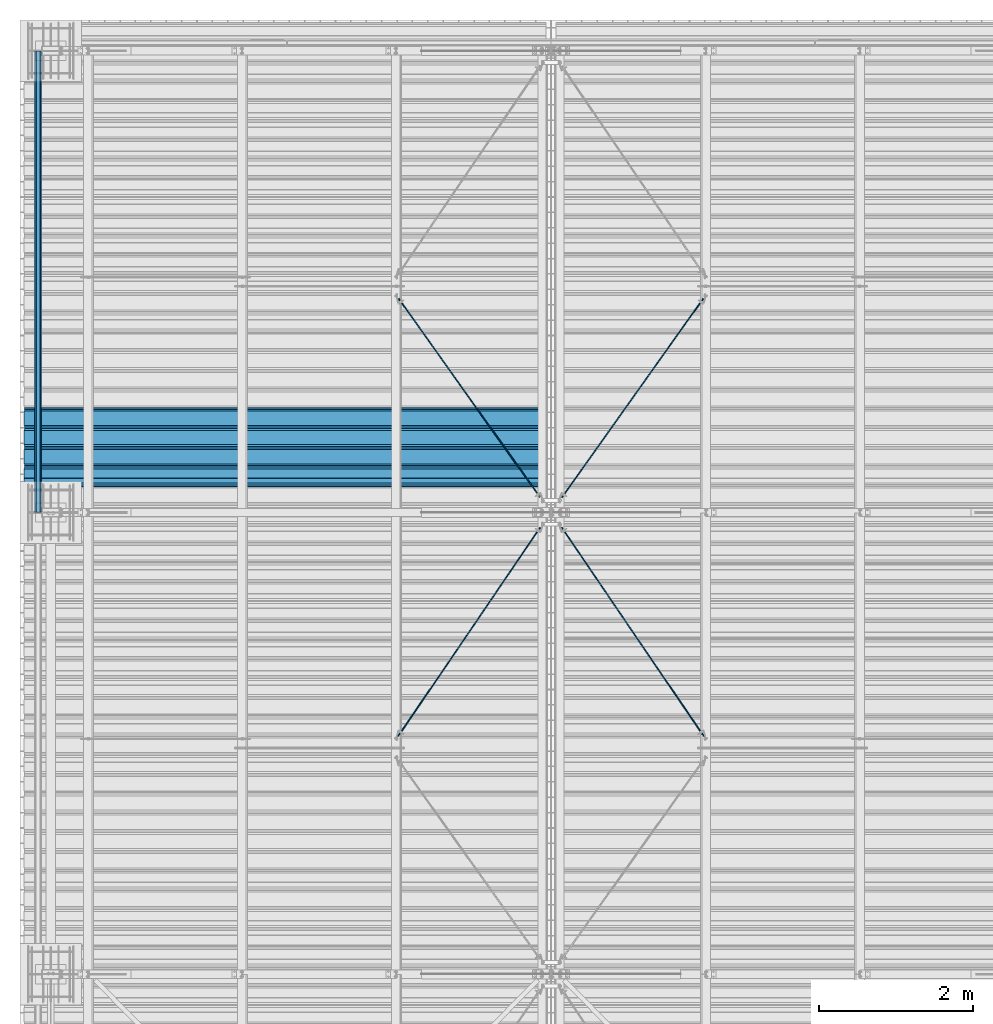
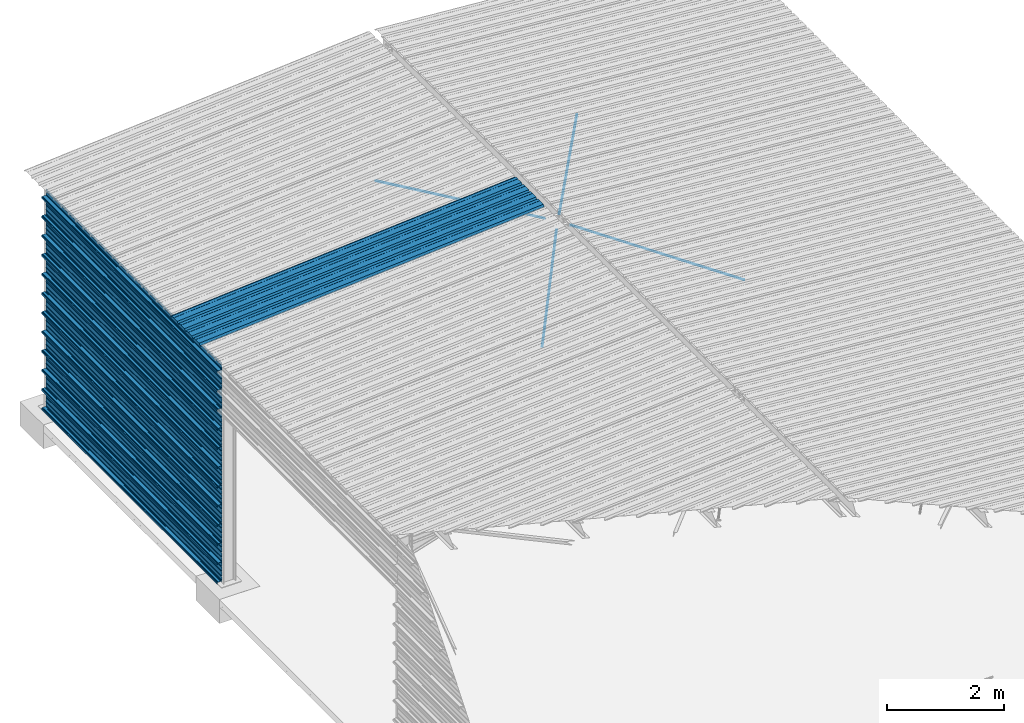
# One storey, part 16 of 70: 17 beams, 17 elements without a shape of their own.
"""IFC2X3 building model written with IfcOpenShell, lengths in millimetres."""

from ifc_helpers import new_model, si_unit, frame, origin_with_axes, origin_2d_with_axis, place, context, subcontext, project, spatial, polyline, circle, outline, extrude, clip, halfspace, material, type_object, element, aggregate, save


model = new_model("IFC2X3")

# Units and contexts
model_context = context("Model", 3, precision=1e-05, world=origin_with_axes())
body_context = subcontext(model_context, "Body", "Model", "MODEL_VIEW")
ifc_project = project(units=[si_unit("LENGTHUNIT", "METRE", prefix="MILLI"), si_unit("AREAUNIT", "SQUARE_METRE"), si_unit("VOLUMEUNIT", "CUBIC_METRE"), si_unit("MASSUNIT", "GRAM", prefix="KILO"), si_unit("TIMEUNIT", "SECOND"), si_unit("PLANEANGLEUNIT", "RADIAN"), si_unit("SOLIDANGLEUNIT", "STERADIAN"), si_unit("THERMODYNAMICTEMPERATUREUNIT", "DEGREE_CELSIUS"), si_unit("LUMINOUSINTENSITYUNIT", "LUMEN")], contexts=[model_context])

# Site, building, storey
site_placement = place(None, origin_with_axes())
site = spatial("IfcSite", under=ifc_project, at=site_placement, CompositionType="ELEMENT")
building_placement = place(site_placement, origin_with_axes())
building = spatial("IfcBuilding", under=site, at=building_placement, Name="Undefined", CompositionType="ELEMENT")
storey_placement = place(building_placement, origin_with_axes())
storey = spatial("IfcBuildingStorey", under=building, at=storey_placement, Name="Undefined", CompositionType="ELEMENT", Elevation=0.0)

# Assembly, beam
assembly_1_placement = place(storey_placement, origin_with_axes())
assembly_1 = element("IfcElementAssembly", 1, at=assembly_1_placement, inside=storey, Name="Steel Assembly", AssemblyPlace="NOTDEFINED", PredefinedType="RIGID_FRAME")
ifc_material = material(Name="STEEL/S235JR")
beam_type_1 = type_object("IfcBeamType", Name="4.40", PredefinedType="NOTDEFINED")
beam_1_placement = place(assembly_1_placement, frame((6436.39248868039, 18850.0, 5336.31760454388), z_axis=(0.0766964990376782, 0.0, -0.997054485489817), x_axis=(-0.997054485489818, 0.0, -0.0766964990376602)))
beam_1 = element("IfcBeam", 2, at=beam_1_placement, type_object=beam_type_1, material=ifc_material, ObjectType="4.40", context=body_context, shape_type="SweptSolid", body=[
    extrude(outline(polyline([(509.415161132813, 19.5000000011705), (490.584838867188, 19.5000000011705), (468.084838867188, -20.4999999988113), (406.585784912109, -20.4999999988113), (404.585784912109, -18.4999999988122), (345.414215087891, -18.4999999988122), (343.414215087891, -20.4999999988113), (281.915161132813, -20.4999999988113), (259.415161132813, 19.5000000011705), (240.584854125977, 19.5000000011705), (218.084854125977, -20.4999999988113), (156.585784912109, -20.4999999988113), (154.585784912109, -18.4999999988122), (95.4142150878906, -18.4999999988122), (93.4142150878906, -20.4999999988113), (31.9151515960693, -20.4999999988113), (9.41515254974365, 19.5000000011705), (-9.41515254974365, 19.5000000011705), (-31.9151515960693, -20.4999999988113), (-93.4142150878906, -20.4999999988113), (-95.4142150878906, -18.4999999988122), (-154.585784912109, -18.4999999988122), (-156.585784912109, -20.4999999988113), (-218.084854125977, -20.4999999988113), (-240.584854125977, 19.5000000011705), (-259.415161132813, 19.5000000011705), (-281.915161132813, -20.4999999988113), (-343.414215087891, -20.4999999988113), (-345.414215087891, -18.4999999988122), (-404.585784912109, -18.4999999988122), (-406.585784912109, -20.4999999988113), (-468.084838867188, -20.4999999988113), (-490.584838867188, 19.5000000011705), (-509.415161132813, 19.5000000011705), (-516.482360839844, 6.9361057293263), (-517.353942871094, 7.42636680720625), (-510.0, 20.5000000011705), (-490.0, 20.5000000011705), (-467.5, -19.4999999988122), (-407.0, -19.4999999988122), (-405.0, -17.4999999988131), (-345.0, -17.4999999988131), (-343.0, -19.4999999988122), (-282.5, -19.4999999988122), (-260.0, 20.5000000011705), (-240.0, 20.5000000011705), (-217.5, -19.4999999988122), (-157.0, -19.4999999988122), (-155.0, -17.4999999988131), (-95.0, -17.4999999988131), (-93.0, -19.4999999988122), (-32.5, -19.4999999988122), (-10.0, 20.5000000011705), (10.0, 20.5000000011705), (32.5, -19.4999999988122), (93.0, -19.4999999988122), (95.0, -17.4999999988131), (155.0, -17.4999999988131), (157.0, -19.4999999988122), (217.5, -19.4999999988122), (240.0, 20.5000000011705), (260.0, 20.5000000011705), (282.5, -19.4999999988122), (343.0, -19.4999999988122), (345.0, -17.4999999988131), (405.0, -17.4999999988131), (407.0, -19.4999999988122), (467.5, -19.4999999988122), (490.0, 20.5000000011705), (510.0, 20.5000000011705), (517.353942871094, 7.42636680720625), (516.482360839844, 6.9361057293263), (509.415161132813, 19.5000000011705)])), frame((6799.99999999733, 2.8421709430404e-14, 0.0), z_axis=(-1.0, 0.0, 0.0), x_axis=(0.0, -1.0, 0.0)), (0.0, 0.0, 1.0), 6800.0),
])
aggregate(assembly_1, [beam_1])

assembly_2_placement = place(storey_placement, origin_with_axes())
assembly_2 = element("IfcElementAssembly", 3, at=assembly_2_placement, inside=storey, Name="Steel Assembly", AssemblyPlace="NOTDEFINED", PredefinedType="RIGID_FRAME")
beam_type_2 = type_object("IfcBeamType", Name="400", PredefinedType="NOTDEFINED")
beam_2_placement = place(assembly_2_placement, frame((-165.499999998334, 18000.0, 4618.17396601053), z_axis=(-1.0, 0.0, 0.0), x_axis=(0.0, 1.0, 0.0)))
beam_2 = element("IfcBeam", 4, at=beam_2_placement, type_object=beam_type_2, material=ifc_material, ObjectType="400", context=body_context, shape_type="Clipping", body=[
    clip(extrude(outline(polyline([(218.25, -24.994083404541), (214.25, -31.8999996185303), (214.25, -45.5), (199.75, -45.5), (194.25, -42.5), (188.75, -45.5), (124.25, -45.5), (114.25, -41.5), (104.25, -45.5), (24.25, -45.5), (14.25, -41.5), (4.25, -45.5), (-75.75, -45.5), (-85.75, -41.5), (-95.75, -45.5), (-160.25, -45.5), (-165.75, -42.5), (-171.25, -45.5), (-185.75, -45.5), (-185.75, -30.711540222168), (-181.75, -23.8111782073975), (-181.75, 23.311637878418), (-185.75, 30.2119998931885), (-185.75, 44.5), (-217.25, 44.5), (-217.25, 34.7999992370605), (-218.25, 34.7999992370605), (-218.25, 45.5), (-184.75, 45.5), (-184.75, 30.480884552002), (-180.75, 23.5805225372314), (-180.75, -24.0800628662109), (-184.75, -30.9804248809814), (-184.75, -44.5), (-171.504989624023, -44.5), (-165.75, -41.360912322998), (-159.995010375977, -44.5), (-95.9425811767578, -44.5), (-85.75, -40.422966003418), (-75.5574188232422, -44.5), (4.05741739273071, -44.5), (14.25, -40.422966003418), (24.4425830841064, -44.5), (104.057418823242, -44.5), (114.25, -40.422966003418), (124.442581176758, -44.5), (188.495010375977, -44.5), (194.25, -41.360912322998), (200.004989624023, -44.5), (213.25, -44.5), (213.25, -31.6313018798828), (217.25, -24.7253856658936), (217.25, 21.7253856658936), (213.25, 28.6313018798828), (213.25, 42.0), (187.25, 42.0), (187.25, 32.5499992370605), (186.25, 32.5499992370605), (186.25, 43.0), (214.25, 43.0), (214.25, 28.8999996185303), (218.25, 21.994083404541), (218.25, -24.994083404541)])), frame((6000.0, 0.0, 0.0), z_axis=(-1.0, 0.0, 0.0), x_axis=(0.0, -1.0, 0.0)), (0.0, 0.0, 1.0), 6000.0), halfspace(frame((5.6843418860808e-14, 36.6804312648874, -45.0000000000003), z_axis=(0.0, -1.0, 0.0), x_axis=(0.0, 0.0, 1.0)), False)),
])
aggregate(assembly_2, [beam_2])

assembly_3_placement = place(storey_placement, origin_with_axes())
assembly_3 = element("IfcElementAssembly", 5, at=assembly_3_placement, inside=storey, Name="Steel Assembly", AssemblyPlace="NOTDEFINED", PredefinedType="RIGID_FRAME")
beam_3_placement = place(assembly_3_placement, frame((-165.499999998485, 18000.0, 4218.17396601053), z_axis=(-1.0, 0.0, 0.0), x_axis=(0.0, 1.0, 0.0)))
beam_3 = element("IfcBeam", 6, at=beam_3_placement, type_object=beam_type_2, material=ifc_material, ObjectType="400", context=body_context, shape_type="SweptSolid", body=[
    extrude(outline(polyline([(218.25, -24.994083404541), (214.25, -31.8999996185303), (214.25, -45.5), (199.75, -45.5), (194.25, -42.5), (188.75, -45.5), (124.25, -45.5), (114.25, -41.5), (104.25, -45.5), (24.25, -45.5), (14.25, -41.5), (4.25, -45.5), (-75.75, -45.5), (-85.75, -41.5), (-95.75, -45.5), (-160.25, -45.5), (-165.75, -42.5), (-171.25, -45.5), (-185.75, -45.5), (-185.75, -30.711540222168), (-181.75, -23.8111782073975), (-181.75, 23.311637878418), (-185.75, 30.2119998931885), (-185.75, 44.5), (-217.25, 44.5), (-217.25, 34.7999992370605), (-218.25, 34.7999992370605), (-218.25, 45.5), (-184.75, 45.5), (-184.75, 30.480884552002), (-180.75, 23.5805225372314), (-180.75, -24.0800628662109), (-184.75, -30.9804248809814), (-184.75, -44.5), (-171.504989624023, -44.5), (-165.75, -41.360912322998), (-159.995010375977, -44.5), (-95.9425811767578, -44.5), (-85.75, -40.422966003418), (-75.5574188232422, -44.5), (4.05741739273071, -44.5), (14.25, -40.422966003418), (24.4425830841064, -44.5), (104.057418823242, -44.5), (114.25, -40.422966003418), (124.442581176758, -44.5), (188.495010375977, -44.5), (194.25, -41.360912322998), (200.004989624023, -44.5), (213.25, -44.5), (213.25, -31.6313018798828), (217.25, -24.7253856658936), (217.25, 21.7253856658936), (213.25, 28.6313018798828), (213.25, 42.0), (187.25, 42.0), (187.25, 32.5499992370605), (186.25, 32.5499992370605), (186.25, 43.0), (214.25, 43.0), (214.25, 28.8999996185303), (218.25, 21.994083404541), (218.25, -24.994083404541)])), frame((6000.0, 0.0, 0.0), z_axis=(-1.0, 0.0, 0.0), x_axis=(0.0, -1.0, 0.0)), (0.0, 0.0, 1.0), 6000.0),
])
aggregate(assembly_3, [beam_3])

assembly_4_placement = place(storey_placement, origin_with_axes())
assembly_4 = element("IfcElementAssembly", 7, at=assembly_4_placement, inside=storey, Name="Steel Assembly", AssemblyPlace="NOTDEFINED", PredefinedType="RIGID_FRAME")
beam_4_placement = place(assembly_4_placement, frame((-165.499999998638, 18000.0, 3818.17396601053), z_axis=(-1.0, 0.0, 0.0), x_axis=(0.0, 1.0, 0.0)))
beam_4 = element("IfcBeam", 8, at=beam_4_placement, type_object=beam_type_2, material=ifc_material, ObjectType="400", context=body_context, shape_type="SweptSolid", body=[
    extrude(outline(polyline([(218.25, -24.994083404541), (214.25, -31.8999996185303), (214.25, -45.5), (199.75, -45.5), (194.25, -42.5), (188.75, -45.5), (124.25, -45.5), (114.25, -41.5), (104.25, -45.5), (24.25, -45.5), (14.25, -41.5), (4.25, -45.5), (-75.75, -45.5), (-85.75, -41.5), (-95.75, -45.5), (-160.25, -45.5), (-165.75, -42.5), (-171.25, -45.5), (-185.75, -45.5), (-185.75, -30.711540222168), (-181.75, -23.8111782073975), (-181.75, 23.311637878418), (-185.75, 30.2119998931885), (-185.75, 44.5), (-217.25, 44.5), (-217.25, 34.7999992370605), (-218.25, 34.7999992370605), (-218.25, 45.5), (-184.75, 45.5), (-184.75, 30.480884552002), (-180.75, 23.5805225372314), (-180.75, -24.0800628662109), (-184.75, -30.9804248809814), (-184.75, -44.5), (-171.504989624023, -44.5), (-165.75, -41.360912322998), (-159.995010375977, -44.5), (-95.9425811767578, -44.5), (-85.75, -40.422966003418), (-75.5574188232422, -44.5), (4.05741739273071, -44.5), (14.25, -40.422966003418), (24.4425830841064, -44.5), (104.057418823242, -44.5), (114.25, -40.422966003418), (124.442581176758, -44.5), (188.495010375977, -44.5), (194.25, -41.360912322998), (200.004989624023, -44.5), (213.25, -44.5), (213.25, -31.6313018798828), (217.25, -24.7253856658936), (217.25, 21.7253856658936), (213.25, 28.6313018798828), (213.25, 42.0), (187.25, 42.0), (187.25, 32.5499992370605), (186.25, 32.5499992370605), (186.25, 43.0), (214.25, 43.0), (214.25, 28.8999996185303), (218.25, 21.994083404541), (218.25, -24.994083404541)])), frame((6000.0, 0.0, 0.0), z_axis=(-1.0, 0.0, 0.0), x_axis=(0.0, -1.0, 0.0)), (0.0, 0.0, 1.0), 6000.0),
])
aggregate(assembly_4, [beam_4])

assembly_5_placement = place(storey_placement, origin_with_axes())
assembly_5 = element("IfcElementAssembly", 9, at=assembly_5_placement, inside=storey, Name="Steel Assembly", AssemblyPlace="NOTDEFINED", PredefinedType="RIGID_FRAME")
beam_5_placement = place(assembly_5_placement, frame((-165.499999998789, 18000.0, 3418.17396601053), z_axis=(-1.0, 0.0, 0.0), x_axis=(0.0, 1.0, 0.0)))
beam_5 = element("IfcBeam", 10, at=beam_5_placement, type_object=beam_type_2, material=ifc_material, ObjectType="400", context=body_context, shape_type="SweptSolid", body=[
    extrude(outline(polyline([(218.25, -24.994083404541), (214.25, -31.8999996185303), (214.25, -45.5), (199.75, -45.5), (194.25, -42.5), (188.75, -45.5), (124.25, -45.5), (114.25, -41.5), (104.25, -45.5), (24.25, -45.5), (14.25, -41.5), (4.25, -45.5), (-75.75, -45.5), (-85.75, -41.5), (-95.75, -45.5), (-160.25, -45.5), (-165.75, -42.5), (-171.25, -45.5), (-185.75, -45.5), (-185.75, -30.711540222168), (-181.75, -23.8111782073975), (-181.75, 23.311637878418), (-185.75, 30.2119998931885), (-185.75, 44.5), (-217.25, 44.5), (-217.25, 34.7999992370605), (-218.25, 34.7999992370605), (-218.25, 45.5), (-184.75, 45.5), (-184.75, 30.480884552002), (-180.75, 23.5805225372314), (-180.75, -24.0800628662109), (-184.75, -30.9804248809814), (-184.75, -44.5), (-171.504989624023, -44.5), (-165.75, -41.360912322998), (-159.995010375977, -44.5), (-95.9425811767578, -44.5), (-85.75, -40.422966003418), (-75.5574188232422, -44.5), (4.05741739273071, -44.5), (14.25, -40.422966003418), (24.4425830841064, -44.5), (104.057418823242, -44.5), (114.25, -40.422966003418), (124.442581176758, -44.5), (188.495010375977, -44.5), (194.25, -41.360912322998), (200.004989624023, -44.5), (213.25, -44.5), (213.25, -31.6313018798828), (217.25, -24.7253856658936), (217.25, 21.7253856658936), (213.25, 28.6313018798828), (213.25, 42.0), (187.25, 42.0), (187.25, 32.5499992370605), (186.25, 32.5499992370605), (186.25, 43.0), (214.25, 43.0), (214.25, 28.8999996185303), (218.25, 21.994083404541), (218.25, -24.994083404541)])), frame((6000.0, 0.0, 0.0), z_axis=(-1.0, 0.0, 0.0), x_axis=(0.0, -1.0, 0.0)), (0.0, 0.0, 1.0), 6000.0),
])
aggregate(assembly_5, [beam_5])

assembly_6_placement = place(storey_placement, origin_with_axes())
assembly_6 = element("IfcElementAssembly", 11, at=assembly_6_placement, inside=storey, Name="Steel Assembly", AssemblyPlace="NOTDEFINED", PredefinedType="RIGID_FRAME")
beam_6_placement = place(assembly_6_placement, frame((-165.49999999894, 18000.0, 3018.17396601053), z_axis=(-1.0, 0.0, 0.0), x_axis=(0.0, 1.0, 0.0)))
beam_6 = element("IfcBeam", 12, at=beam_6_placement, type_object=beam_type_2, material=ifc_material, ObjectType="400", context=body_context, shape_type="SweptSolid", body=[
    extrude(outline(polyline([(218.25, -24.994083404541), (214.25, -31.8999996185303), (214.25, -45.5), (199.75, -45.5), (194.25, -42.5), (188.75, -45.5), (124.25, -45.5), (114.25, -41.5), (104.25, -45.5), (24.25, -45.5), (14.25, -41.5), (4.25, -45.5), (-75.75, -45.5), (-85.75, -41.5), (-95.75, -45.5), (-160.25, -45.5), (-165.75, -42.5), (-171.25, -45.5), (-185.75, -45.5), (-185.75, -30.711540222168), (-181.75, -23.8111782073975), (-181.75, 23.311637878418), (-185.75, 30.2119998931885), (-185.75, 44.5), (-217.25, 44.5), (-217.25, 34.7999992370605), (-218.25, 34.7999992370605), (-218.25, 45.5), (-184.75, 45.5), (-184.75, 30.480884552002), (-180.75, 23.5805225372314), (-180.75, -24.0800628662109), (-184.75, -30.9804248809814), (-184.75, -44.5), (-171.504989624023, -44.5), (-165.75, -41.360912322998), (-159.995010375977, -44.5), (-95.9425811767578, -44.5), (-85.75, -40.422966003418), (-75.5574188232422, -44.5), (4.05741739273071, -44.5), (14.25, -40.422966003418), (24.4425830841064, -44.5), (104.057418823242, -44.5), (114.25, -40.422966003418), (124.442581176758, -44.5), (188.495010375977, -44.5), (194.25, -41.360912322998), (200.004989624023, -44.5), (213.25, -44.5), (213.25, -31.6313018798828), (217.25, -24.7253856658936), (217.25, 21.7253856658936), (213.25, 28.6313018798828), (213.25, 42.0), (187.25, 42.0), (187.25, 32.5499992370605), (186.25, 32.5499992370605), (186.25, 43.0), (214.25, 43.0), (214.25, 28.8999996185303), (218.25, 21.994083404541), (218.25, -24.994083404541)])), frame((6000.0, 0.0, 0.0), z_axis=(-1.0, 0.0, 0.0), x_axis=(0.0, -1.0, 0.0)), (0.0, 0.0, 1.0), 6000.0),
])
aggregate(assembly_6, [beam_6])

assembly_7_placement = place(storey_placement, origin_with_axes())
assembly_7 = element("IfcElementAssembly", 13, at=assembly_7_placement, inside=storey, Name="Steel Assembly", AssemblyPlace="NOTDEFINED", PredefinedType="RIGID_FRAME")
beam_7_placement = place(assembly_7_placement, frame((-165.499999999092, 18000.0, 2618.17396601053), z_axis=(-1.0, 0.0, 0.0), x_axis=(0.0, 1.0, 0.0)))
beam_7 = element("IfcBeam", 14, at=beam_7_placement, type_object=beam_type_2, material=ifc_material, ObjectType="400", context=body_context, shape_type="SweptSolid", body=[
    extrude(outline(polyline([(218.25, -24.994083404541), (214.25, -31.8999996185303), (214.25, -45.5), (199.75, -45.5), (194.25, -42.5), (188.75, -45.5), (124.25, -45.5), (114.25, -41.5), (104.25, -45.5), (24.25, -45.5), (14.25, -41.5), (4.25, -45.5), (-75.75, -45.5), (-85.75, -41.5), (-95.75, -45.5), (-160.25, -45.5), (-165.75, -42.5), (-171.25, -45.5), (-185.75, -45.5), (-185.75, -30.711540222168), (-181.75, -23.8111782073975), (-181.75, 23.311637878418), (-185.75, 30.2119998931885), (-185.75, 44.5), (-217.25, 44.5), (-217.25, 34.7999992370605), (-218.25, 34.7999992370605), (-218.25, 45.5), (-184.75, 45.5), (-184.75, 30.480884552002), (-180.75, 23.5805225372314), (-180.75, -24.0800628662109), (-184.75, -30.9804248809814), (-184.75, -44.5), (-171.504989624023, -44.5), (-165.75, -41.360912322998), (-159.995010375977, -44.5), (-95.9425811767578, -44.5), (-85.75, -40.422966003418), (-75.5574188232422, -44.5), (4.05741739273071, -44.5), (14.25, -40.422966003418), (24.4425830841064, -44.5), (104.057418823242, -44.5), (114.25, -40.422966003418), (124.442581176758, -44.5), (188.495010375977, -44.5), (194.25, -41.360912322998), (200.004989624023, -44.5), (213.25, -44.5), (213.25, -31.6313018798828), (217.25, -24.7253856658936), (217.25, 21.7253856658936), (213.25, 28.6313018798828), (213.25, 42.0), (187.25, 42.0), (187.25, 32.5499992370605), (186.25, 32.5499992370605), (186.25, 43.0), (214.25, 43.0), (214.25, 28.8999996185303), (218.25, 21.994083404541), (218.25, -24.994083404541)])), frame((6000.0, 0.0, 0.0), z_axis=(-1.0, 0.0, 0.0), x_axis=(0.0, -1.0, 0.0)), (0.0, 0.0, 1.0), 6000.0),
])
aggregate(assembly_7, [beam_7])

assembly_8_placement = place(storey_placement, origin_with_axes())
assembly_8 = element("IfcElementAssembly", 15, at=assembly_8_placement, inside=storey, Name="Steel Assembly", AssemblyPlace="NOTDEFINED", PredefinedType="RIGID_FRAME")
beam_8_placement = place(assembly_8_placement, frame((-165.499999999243, 18000.0, 2218.17396601053), z_axis=(-1.0, 0.0, 0.0), x_axis=(0.0, 1.0, 0.0)))
beam_8 = element("IfcBeam", 16, at=beam_8_placement, type_object=beam_type_2, material=ifc_material, ObjectType="400", context=body_context, shape_type="SweptSolid", body=[
    extrude(outline(polyline([(218.25, -24.994083404541), (214.25, -31.8999996185303), (214.25, -45.5), (199.75, -45.5), (194.25, -42.5), (188.75, -45.5), (124.25, -45.5), (114.25, -41.5), (104.25, -45.5), (24.25, -45.5), (14.25, -41.5), (4.25, -45.5), (-75.75, -45.5), (-85.75, -41.5), (-95.75, -45.5), (-160.25, -45.5), (-165.75, -42.5), (-171.25, -45.5), (-185.75, -45.5), (-185.75, -30.711540222168), (-181.75, -23.8111782073975), (-181.75, 23.311637878418), (-185.75, 30.2119998931885), (-185.75, 44.5), (-217.25, 44.5), (-217.25, 34.7999992370605), (-218.25, 34.7999992370605), (-218.25, 45.5), (-184.75, 45.5), (-184.75, 30.480884552002), (-180.75, 23.5805225372314), (-180.75, -24.0800628662109), (-184.75, -30.9804248809814), (-184.75, -44.5), (-171.504989624023, -44.5), (-165.75, -41.360912322998), (-159.995010375977, -44.5), (-95.9425811767578, -44.5), (-85.75, -40.422966003418), (-75.5574188232422, -44.5), (4.05741739273071, -44.5), (14.25, -40.422966003418), (24.4425830841064, -44.5), (104.057418823242, -44.5), (114.25, -40.422966003418), (124.442581176758, -44.5), (188.495010375977, -44.5), (194.25, -41.360912322998), (200.004989624023, -44.5), (213.25, -44.5), (213.25, -31.6313018798828), (217.25, -24.7253856658936), (217.25, 21.7253856658936), (213.25, 28.6313018798828), (213.25, 42.0), (187.25, 42.0), (187.25, 32.5499992370605), (186.25, 32.5499992370605), (186.25, 43.0), (214.25, 43.0), (214.25, 28.8999996185303), (218.25, 21.994083404541), (218.25, -24.994083404541)])), frame((6000.0, 0.0, 0.0), z_axis=(-1.0, 0.0, 0.0), x_axis=(0.0, -1.0, 0.0)), (0.0, 0.0, 1.0), 6000.0),
])
aggregate(assembly_8, [beam_8])

assembly_9_placement = place(storey_placement, origin_with_axes())
assembly_9 = element("IfcElementAssembly", 17, at=assembly_9_placement, inside=storey, Name="Steel Assembly", AssemblyPlace="NOTDEFINED", PredefinedType="RIGID_FRAME")
beam_9_placement = place(assembly_9_placement, frame((-165.499999999396, 18000.0, 1818.17396601053), z_axis=(-1.0, 0.0, 0.0), x_axis=(0.0, 1.0, 0.0)))
beam_9 = element("IfcBeam", 18, at=beam_9_placement, type_object=beam_type_2, material=ifc_material, ObjectType="400", context=body_context, shape_type="SweptSolid", body=[
    extrude(outline(polyline([(218.25, -24.994083404541), (214.25, -31.8999996185303), (214.25, -45.5), (199.75, -45.5), (194.25, -42.5), (188.75, -45.5), (124.25, -45.5), (114.25, -41.5), (104.25, -45.5), (24.25, -45.5), (14.25, -41.5), (4.25, -45.5), (-75.75, -45.5), (-85.75, -41.5), (-95.75, -45.5), (-160.25, -45.5), (-165.75, -42.5), (-171.25, -45.5), (-185.75, -45.5), (-185.75, -30.711540222168), (-181.75, -23.8111782073975), (-181.75, 23.311637878418), (-185.75, 30.2119998931885), (-185.75, 44.5), (-217.25, 44.5), (-217.25, 34.7999992370605), (-218.25, 34.7999992370605), (-218.25, 45.5), (-184.75, 45.5), (-184.75, 30.480884552002), (-180.75, 23.5805225372314), (-180.75, -24.0800628662109), (-184.75, -30.9804248809814), (-184.75, -44.5), (-171.504989624023, -44.5), (-165.75, -41.360912322998), (-159.995010375977, -44.5), (-95.9425811767578, -44.5), (-85.75, -40.422966003418), (-75.5574188232422, -44.5), (4.05741739273071, -44.5), (14.25, -40.422966003418), (24.4425830841064, -44.5), (104.057418823242, -44.5), (114.25, -40.422966003418), (124.442581176758, -44.5), (188.495010375977, -44.5), (194.25, -41.360912322998), (200.004989624023, -44.5), (213.25, -44.5), (213.25, -31.6313018798828), (217.25, -24.7253856658936), (217.25, 21.7253856658936), (213.25, 28.6313018798828), (213.25, 42.0), (187.25, 42.0), (187.25, 32.5499992370605), (186.25, 32.5499992370605), (186.25, 43.0), (214.25, 43.0), (214.25, 28.8999996185303), (218.25, 21.994083404541), (218.25, -24.994083404541)])), frame((6000.0, 0.0, 0.0), z_axis=(-1.0, 0.0, 0.0), x_axis=(0.0, -1.0, 0.0)), (0.0, 0.0, 1.0), 6000.0),
])
aggregate(assembly_9, [beam_9])

assembly_10_placement = place(storey_placement, origin_with_axes())
assembly_10 = element("IfcElementAssembly", 19, at=assembly_10_placement, inside=storey, Name="Steel Assembly", AssemblyPlace="NOTDEFINED", PredefinedType="RIGID_FRAME")
beam_10_placement = place(assembly_10_placement, frame((-165.499999999547, 18000.0, 1418.17396601053), z_axis=(-1.0, 0.0, 0.0), x_axis=(0.0, 1.0, 0.0)))
beam_10 = element("IfcBeam", 20, at=beam_10_placement, type_object=beam_type_2, material=ifc_material, ObjectType="400", context=body_context, shape_type="SweptSolid", body=[
    extrude(outline(polyline([(218.25, -24.994083404541), (214.25, -31.8999996185303), (214.25, -45.5), (199.75, -45.5), (194.25, -42.5), (188.75, -45.5), (124.25, -45.5), (114.25, -41.5), (104.25, -45.5), (24.25, -45.5), (14.25, -41.5), (4.25, -45.5), (-75.75, -45.5), (-85.75, -41.5), (-95.75, -45.5), (-160.25, -45.5), (-165.75, -42.5), (-171.25, -45.5), (-185.75, -45.5), (-185.75, -30.711540222168), (-181.75, -23.8111782073975), (-181.75, 23.311637878418), (-185.75, 30.2119998931885), (-185.75, 44.5), (-217.25, 44.5), (-217.25, 34.7999992370605), (-218.25, 34.7999992370605), (-218.25, 45.5), (-184.75, 45.5), (-184.75, 30.480884552002), (-180.75, 23.5805225372314), (-180.75, -24.0800628662109), (-184.75, -30.9804248809814), (-184.75, -44.5), (-171.504989624023, -44.5), (-165.75, -41.360912322998), (-159.995010375977, -44.5), (-95.9425811767578, -44.5), (-85.75, -40.422966003418), (-75.5574188232422, -44.5), (4.05741739273071, -44.5), (14.25, -40.422966003418), (24.4425830841064, -44.5), (104.057418823242, -44.5), (114.25, -40.422966003418), (124.442581176758, -44.5), (188.495010375977, -44.5), (194.25, -41.360912322998), (200.004989624023, -44.5), (213.25, -44.5), (213.25, -31.6313018798828), (217.25, -24.7253856658936), (217.25, 21.7253856658936), (213.25, 28.6313018798828), (213.25, 42.0), (187.25, 42.0), (187.25, 32.5499992370605), (186.25, 32.5499992370605), (186.25, 43.0), (214.25, 43.0), (214.25, 28.8999996185303), (218.25, 21.994083404541), (218.25, -24.994083404541)])), frame((6000.0, 0.0, 0.0), z_axis=(-1.0, 0.0, 0.0), x_axis=(0.0, -1.0, 0.0)), (0.0, 0.0, 1.0), 6000.0),
])
aggregate(assembly_10, [beam_10])

assembly_11_placement = place(storey_placement, origin_with_axes())
assembly_11 = element("IfcElementAssembly", 21, at=assembly_11_placement, inside=storey, Name="Steel Assembly", AssemblyPlace="NOTDEFINED", PredefinedType="RIGID_FRAME")
beam_11_placement = place(assembly_11_placement, frame((-165.499999999698, 18000.0, 1018.17396601053), z_axis=(-1.0, 0.0, 0.0), x_axis=(0.0, 1.0, 0.0)))
beam_11 = element("IfcBeam", 22, at=beam_11_placement, type_object=beam_type_2, material=ifc_material, ObjectType="400", context=body_context, shape_type="SweptSolid", body=[
    extrude(outline(polyline([(218.25, -24.994083404541), (214.25, -31.8999996185303), (214.25, -45.5), (199.75, -45.5), (194.25, -42.5), (188.75, -45.5), (124.25, -45.5), (114.25, -41.5), (104.25, -45.5), (24.25, -45.5), (14.25, -41.5), (4.25, -45.5), (-75.75, -45.5), (-85.75, -41.5), (-95.75, -45.5), (-160.25, -45.5), (-165.75, -42.5), (-171.25, -45.5), (-185.75, -45.5), (-185.75, -30.711540222168), (-181.75, -23.8111782073975), (-181.75, 23.311637878418), (-185.75, 30.2119998931885), (-185.75, 44.5), (-217.25, 44.5), (-217.25, 34.7999992370605), (-218.25, 34.7999992370605), (-218.25, 45.5), (-184.75, 45.5), (-184.75, 30.480884552002), (-180.75, 23.5805225372314), (-180.75, -24.0800628662109), (-184.75, -30.9804248809814), (-184.75, -44.5), (-171.504989624023, -44.5), (-165.75, -41.360912322998), (-159.995010375977, -44.5), (-95.9425811767578, -44.5), (-85.75, -40.422966003418), (-75.5574188232422, -44.5), (4.05741739273071, -44.5), (14.25, -40.422966003418), (24.4425830841064, -44.5), (104.057418823242, -44.5), (114.25, -40.422966003418), (124.442581176758, -44.5), (188.495010375977, -44.5), (194.25, -41.360912322998), (200.004989624023, -44.5), (213.25, -44.5), (213.25, -31.6313018798828), (217.25, -24.7253856658936), (217.25, 21.7253856658936), (213.25, 28.6313018798828), (213.25, 42.0), (187.25, 42.0), (187.25, 32.5499992370605), (186.25, 32.5499992370605), (186.25, 43.0), (214.25, 43.0), (214.25, 28.8999996185303), (218.25, 21.994083404541), (218.25, -24.994083404541)])), frame((6000.0, 0.0, 0.0), z_axis=(-1.0, 0.0, 0.0), x_axis=(0.0, -1.0, 0.0)), (0.0, 0.0, 1.0), 6000.0),
])
aggregate(assembly_11, [beam_11])

assembly_12_placement = place(storey_placement, origin_with_axes())
assembly_12 = element("IfcElementAssembly", 23, at=assembly_12_placement, inside=storey, Name="Steel Assembly", AssemblyPlace="NOTDEFINED", PredefinedType="RIGID_FRAME")
beam_12_placement = place(assembly_12_placement, frame((-165.499999999851, 18000.0, 618.173966010527), z_axis=(-1.0, 0.0, 0.0), x_axis=(0.0, 1.0, 0.0)))
beam_12 = element("IfcBeam", 24, at=beam_12_placement, type_object=beam_type_2, material=ifc_material, ObjectType="400", context=body_context, shape_type="SweptSolid", body=[
    extrude(outline(polyline([(218.25, -24.994083404541), (214.25, -31.8999996185303), (214.25, -45.5), (199.75, -45.5), (194.25, -42.5), (188.75, -45.5), (124.25, -45.5), (114.25, -41.5), (104.25, -45.5), (24.25, -45.5), (14.25, -41.5), (4.25, -45.5), (-75.75, -45.5), (-85.75, -41.5), (-95.75, -45.5), (-160.25, -45.5), (-165.75, -42.5), (-171.25, -45.5), (-185.75, -45.5), (-185.75, -30.711540222168), (-181.75, -23.8111782073975), (-181.75, 23.311637878418), (-185.75, 30.2119998931885), (-185.75, 44.5), (-217.25, 44.5), (-217.25, 34.7999992370605), (-218.25, 34.7999992370605), (-218.25, 45.5), (-184.75, 45.5), (-184.75, 30.480884552002), (-180.75, 23.5805225372314), (-180.75, -24.0800628662109), (-184.75, -30.9804248809814), (-184.75, -44.5), (-171.504989624023, -44.5), (-165.75, -41.360912322998), (-159.995010375977, -44.5), (-95.9425811767578, -44.5), (-85.75, -40.422966003418), (-75.5574188232422, -44.5), (4.05741739273071, -44.5), (14.25, -40.422966003418), (24.4425830841064, -44.5), (104.057418823242, -44.5), (114.25, -40.422966003418), (124.442581176758, -44.5), (188.495010375977, -44.5), (194.25, -41.360912322998), (200.004989624023, -44.5), (213.25, -44.5), (213.25, -31.6313018798828), (217.25, -24.7253856658936), (217.25, 21.7253856658936), (213.25, 28.6313018798828), (213.25, 42.0), (187.25, 42.0), (187.25, 32.5499992370605), (186.25, 32.5499992370605), (186.25, 43.0), (214.25, 43.0), (214.25, 28.8999996185303), (218.25, 21.994083404541), (218.25, -24.994083404541)])), frame((6000.0, 0.0, 0.0), z_axis=(-1.0, 0.0, 0.0), x_axis=(0.0, -1.0, 0.0)), (0.0, 0.0, 1.0), 6000.0),
])
aggregate(assembly_12, [beam_12])

assembly_13_placement = place(storey_placement, origin_with_axes())
assembly_13 = element("IfcElementAssembly", 25, at=assembly_13_placement, inside=storey, Name="Steel Assembly", AssemblyPlace="NOTDEFINED", PredefinedType="RIGID_FRAME")
beam_13_placement = place(assembly_13_placement, frame((-165.500000000002, 18000.0, 218.173966010527), z_axis=(-1.0, 0.0, 0.0), x_axis=(0.0, 1.0, 0.0)))
beam_13 = element("IfcBeam", 26, at=beam_13_placement, type_object=beam_type_2, material=ifc_material, ObjectType="400", context=body_context, shape_type="SweptSolid", body=[
    extrude(outline(polyline([(218.25, -24.994083404541), (214.25, -31.8999996185303), (214.25, -45.5), (199.75, -45.5), (194.25, -42.5), (188.75, -45.5), (124.25, -45.5), (114.25, -41.5), (104.25, -45.5), (24.25, -45.5), (14.25, -41.5), (4.25, -45.5), (-75.75, -45.5), (-85.75, -41.5), (-95.75, -45.5), (-160.25, -45.5), (-165.75, -42.5), (-171.25, -45.5), (-185.75, -45.5), (-185.75, -30.711540222168), (-181.75, -23.8111782073975), (-181.75, 23.311637878418), (-185.75, 30.2119998931885), (-185.75, 44.5), (-217.25, 44.5), (-217.25, 34.7999992370605), (-218.25, 34.7999992370605), (-218.25, 45.5), (-184.75, 45.5), (-184.75, 30.480884552002), (-180.75, 23.5805225372314), (-180.75, -24.0800628662109), (-184.75, -30.9804248809814), (-184.75, -44.5), (-171.504989624023, -44.5), (-165.75, -41.360912322998), (-159.995010375977, -44.5), (-95.9425811767578, -44.5), (-85.75, -40.422966003418), (-75.5574188232422, -44.5), (4.05741739273071, -44.5), (14.25, -40.422966003418), (24.4425830841064, -44.5), (104.057418823242, -44.5), (114.25, -40.422966003418), (124.442581176758, -44.5), (188.495010375977, -44.5), (194.25, -41.360912322998), (200.004989624023, -44.5), (213.25, -44.5), (213.25, -31.6313018798828), (217.25, -24.7253856658936), (217.25, 21.7253856658936), (213.25, 28.6313018798828), (213.25, 42.0), (187.25, 42.0), (187.25, 32.5499992370605), (186.25, 32.5499992370605), (186.25, 43.0), (214.25, 43.0), (214.25, 28.8999996185303), (218.25, 21.994083404541), (218.25, -24.994083404541)])), frame((6000.0, 0.0, 0.0), z_axis=(-1.0, 0.0, 0.0), x_axis=(0.0, -1.0, 0.0)), (0.0, 0.0, 1.0), 6000.0),
])
aggregate(assembly_13, [beam_13])

assembly_14_placement = place(storey_placement, origin_with_axes())
assembly_14 = element("IfcElementAssembly", 27, at=assembly_14_placement, inside=storey, Name="Steel Assembly", AssemblyPlace="NOTDEFINED", PredefinedType="RIGID_FRAME")
beam_type_3 = type_object("IfcBeamType", Name="D14", PredefinedType="NOTDEFINED")
beam_14_placement = place(assembly_14_placement, frame((6359.25890438012, 17802.5634203525, 5199.49872615087), z_axis=(0.0766964990376782, 0.0, -0.997054485489817), x_axis=(-0.5623502269338, -0.825766911902807, -0.0432577099949295)))
beam_14 = element("IfcBeam", 28, at=beam_14_placement, type_object=beam_type_3, material=ifc_material, Name="THREAD60MM", ObjectType="D14", context=body_context, shape_type="SweptSolid", body=[
    extrude(circle(Radius=7.0, at=origin_2d_with_axis()), frame((3281.00152682824, 4.52755280255808e-12, -9.09494701772928e-13), z_axis=(-1.0, 0.0, 0.0), x_axis=(0.0, -1.0, 0.0)), (0.0, 0.0, 1.0), 3281.0),
])
aggregate(assembly_14, [beam_14])

assembly_15_placement = place(storey_placement, origin_with_axes())
assembly_15 = element("IfcElementAssembly", 29, at=assembly_15_placement, inside=storey, Name="Steel Assembly", AssemblyPlace="NOTDEFINED", PredefinedType="RIGID_FRAME")
beam_15_placement = place(assembly_15_placement, frame((6355.84996395203, 18200.1867550433, 5199.23649996745), z_axis=(0.0766964990376782, 0.0, -0.997054485489817), x_axis=(-0.57921819911489, 0.813953996161451, -0.0445552460088377)))
beam_15 = element("IfcBeam", 30, at=beam_15_placement, type_object=beam_type_3, material=ifc_material, Name="THREAD60MM", ObjectType="D14", context=body_context, shape_type="SweptSolid", body=[
    extrude(circle(Radius=7.0, at=origin_2d_with_axis()), frame((3167.25452569042, -1.12633370992234e-13, -9.09494701772928e-13), z_axis=(-1.0, 0.0, 0.0), x_axis=(0.0, -1.0, 0.0)), (0.0, 0.0, 1.0), 3167.25),
])
aggregate(assembly_15, [beam_15])

assembly_16_placement = place(storey_placement, origin_with_axes())
assembly_16 = element("IfcElementAssembly", 31, at=assembly_16_placement, inside=storey, Name="Steel Assembly", AssemblyPlace="NOTDEFINED", PredefinedType="RIGID_FRAME")
beam_16_placement = place(assembly_16_placement, frame((6640.31553870171, 17803.1883170902, 5199.5314612986), z_axis=(-0.0766964990376782, 0.0, -0.997054485489817), x_axis=(0.562350226933823, -0.825766911902794, -0.0432577099948882)))
beam_16 = element("IfcBeam", 32, at=beam_16_placement, type_object=beam_type_3, material=ifc_material, Name="THREAD60MM", ObjectType="D14", context=body_context, shape_type="SweptSolid", body=[
    extrude(circle(Radius=7.0, at=origin_2d_with_axis()), frame((3281.75827395462, 2.16198922654455e-12, 0.0), z_axis=(-1.0, 0.0, 0.0), x_axis=(0.0, -1.0, 0.0)), (0.0, 0.0, 1.0), 3281.76),
])
aggregate(assembly_16, [beam_16])

assembly_17_placement = place(storey_placement, origin_with_axes())
assembly_17 = element("IfcElementAssembly", 33, at=assembly_17_placement, inside=storey, Name="Steel Assembly", AssemblyPlace="NOTDEFINED", PredefinedType="RIGID_FRAME")
beam_17_placement = place(assembly_17_placement, frame((6641.8391316081, 18196.9393261726, 5199.41426184843), z_axis=(-0.0766964990376782, 0.0, -0.997054485489817), x_axis=(0.57921819911489, 0.813953996161451, -0.0445552460088378)))
beam_17 = element("IfcBeam", 34, at=beam_17_placement, type_object=beam_type_3, material=ifc_material, Name="THREAD60MM", ObjectType="D14", context=body_context, shape_type="SweptSolid", body=[
    extrude(circle(Radius=7.0, at=origin_2d_with_axis()), frame((3171.24422152932, 2.51393606515222e-12, 0.0), z_axis=(-1.0, 0.0, 0.0), x_axis=(0.0, -1.0, 0.0)), (0.0, 0.0, 1.0), 3171.24),
])
aggregate(assembly_17, [beam_17])

save(model, "model.ifc")
